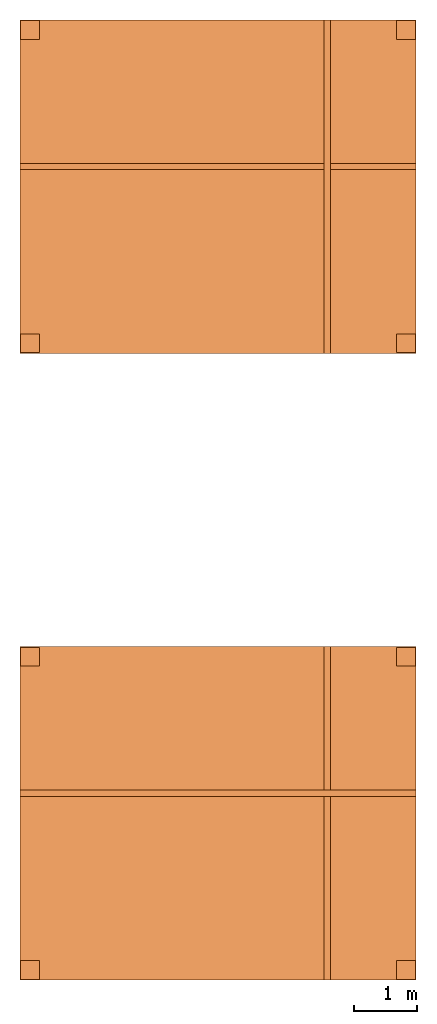
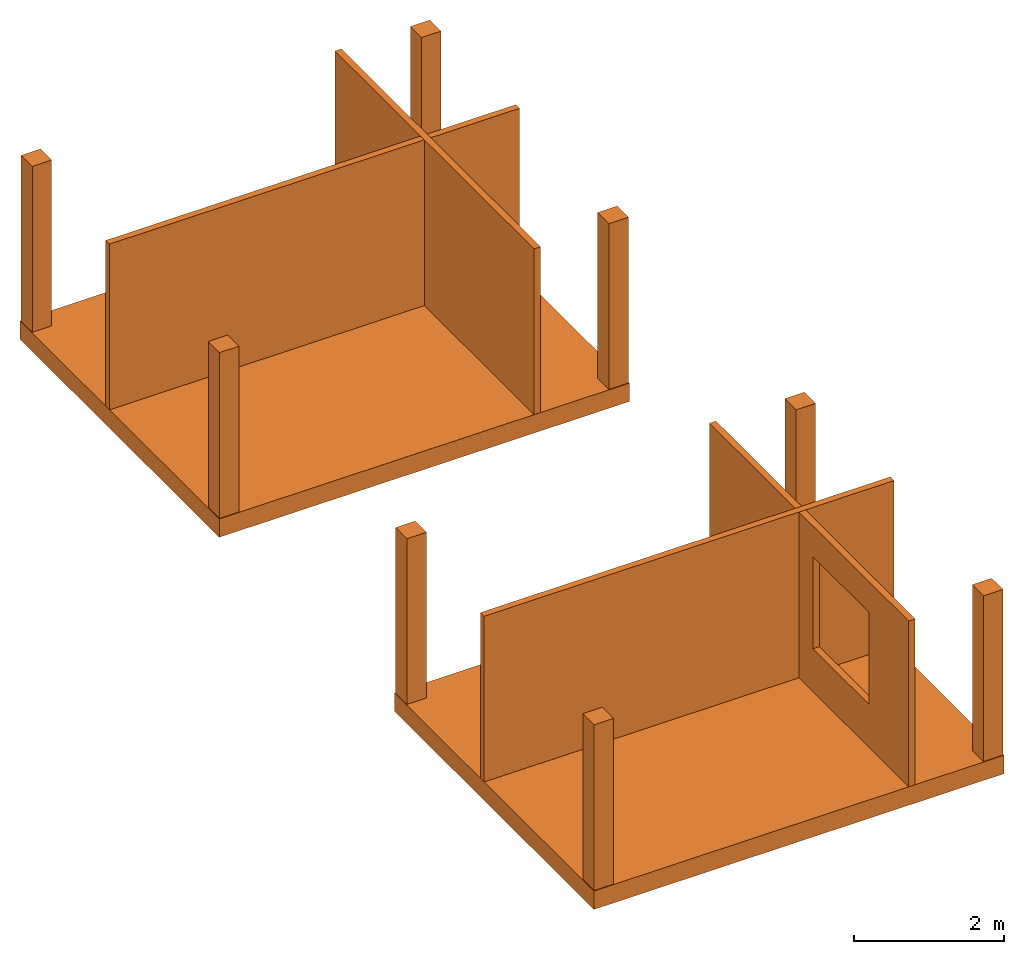
# One storey: 14 proxies, 1 opening.
"""IFC2X3 building model written with IfcOpenShell, lengths in metres."""

from ifc_helpers import new_model, entity, si_unit, converted_unit, derived_unit, money_unit, direction, frame, origin_with_axes, origin_2d_with_axis, place, context, subcontext, project, spatial, polyline, rectangle, outline, extrude, material, type_object, element, save


model = new_model("IFC2X3")

# Units and contexts
model_context = context("Model", 3, precision=1e-05, world=origin_with_axes(), true_north=direction((0.0, 1.0)))
body_context = subcontext(model_context, "Body", "Model", "MODEL_VIEW")
ifc_project = project(units=[si_unit("LENGTHUNIT", "METRE"), si_unit("AREAUNIT", "SQUARE_METRE"), si_unit("VOLUMEUNIT", "CUBIC_METRE"), converted_unit("PLANEANGLEUNIT", "DEGREE", entity("IfcPlaneAngleMeasure", 0.0174532925199433), si_unit("PLANEANGLEUNIT", "RADIAN"), dimensions=[0, 0, 0, 0, 0, 0, 0]), money_unit("EUR"), converted_unit("TIMEUNIT", "Year", entity("IfcTimeMeasure", 31557600.0), si_unit("TIMEUNIT", "SECOND"), dimensions=[0, 0, 1, 0, 0, 0, 0]), si_unit("MASSUNIT", "GRAM", prefix="KILO"), si_unit("THERMODYNAMICTEMPERATUREUNIT", "DEGREE_CELSIUS"), si_unit("LUMINOUSINTENSITYUNIT", "LUMEN"), si_unit("ENERGYUNIT", "JOULE", prefix="MEGA"), derived_unit("THERMALCONDUCTANCEUNIT", [(si_unit("POWERUNIT", "WATT"), 1), (si_unit("LENGTHUNIT", "METRE"), -1), (si_unit("THERMODYNAMICTEMPERATUREUNIT", "KELVIN"), -1)]), derived_unit("SPECIFICHEATCAPACITYUNIT", [(si_unit("ENERGYUNIT", "JOULE"), 1), (si_unit("MASSUNIT", "GRAM", prefix="KILO"), -1), (si_unit("THERMODYNAMICTEMPERATUREUNIT", "KELVIN"), -1)]), derived_unit("MASSDENSITYUNIT", [(si_unit("MASSUNIT", "GRAM", prefix="KILO"), 1), (si_unit("VOLUMEUNIT", "CUBIC_METRE"), -1)])], contexts=[model_context])

# Site, building, storey
site_placement = place(None, origin_with_axes())
site = spatial("IfcSite", under=ifc_project, at=site_placement, CompositionType="ELEMENT")
building_placement = place(site_placement, origin_with_axes())
building = spatial("IfcBuilding", under=site, at=building_placement, Name="Edificio", CompositionType="ELEMENT")
storey_placement = place(building_placement, frame((0.0, 0.0, 3.0), z_axis=(0.0, 0.0, 1.0), x_axis=(1.0, 0.0, 0.0)))
storey = spatial("IfcBuildingStorey", under=building, at=storey_placement, Name="L01", CompositionType="ELEMENT", Elevation=3.0)

# Proxies
ifc_material_1 = material(Name="Cemento - Strutturale")
building_element_proxy_type_1 = type_object("IfcBuildingElementProxyType", Name="Cemento - Strutturale 300", PredefinedType="NOTDEFINED")
for number, where, z_axis, x_axis, name in (
    (1, (-0.16, -0.16, 0.0), (0.0, 0.0, 1.0), (1.0, 0.0, 0.0), "SOL_001"),
    (2, (-0.1599999999999991, 9.84, 0.0), (0.0, 0.0, 1.0), (1.0, 0.0, 0.0), "SOL_005"),
):
    element("IfcBuildingElementProxy", number, at=place(storey_placement, frame(where, z_axis=z_axis, x_axis=x_axis)), inside=storey, type_object=building_element_proxy_type_1, material=ifc_material_1, Name=name, context=body_context, shape_type="SweptSolid", body=[
        extrude(outline(polyline([(0.0, 0.0), (6.32, 0.0), (6.32, 5.32), (0.0, 5.32), (0.0, 0.0)])), frame((0.0, 0.0, -0.3), z_axis=(0.0, 0.0, 1.0), x_axis=(1.0, 0.0, 0.0)), (0.0, 0.0, 1.0), 0.3),
    ])
ifc_material_2 = material(Name="Mattone")
building_element_proxy_type_2 = type_object("IfcBuildingElementProxyType", Name="Mattone 100", PredefinedType="NOTDEFINED")
proxy_1_placement = place(storey_placement, frame((-0.16, 2.771048843802536, 0.0), z_axis=(0.0, 0.0, 1.0), x_axis=(1.0, 0.0, 0.0)))
element("IfcBuildingElementProxy", 3, at=proxy_1_placement, inside=storey, type_object=building_element_proxy_type_2, material=ifc_material_2, Name="MUR_010", context=body_context, shape_type="SweptSolid", body=[
    extrude(outline(polyline([(0.0, 0.0), (6.32, 0.0), (6.32, 0.1000000000000001), (0.0, 0.1000000000000001), (0.0, 0.0)])), origin_with_axes(), (0.0, 0.0, 1.0), 2.7),
])

# Proxy, opening
proxy_2_placement = place(storey_placement, frame((4.69193911373474, 5.16, 0.0), z_axis=(0.0, 0.0, 1.0), x_axis=(0.0, -1.0, 0.0)))
proxy_2 = element("IfcBuildingElementProxy", 4, at=proxy_2_placement, inside=storey, type_object=building_element_proxy_type_2, material=ifc_material_2, Name="MUR_011", context=body_context, shape_type="SweptSolid", body=[
    extrude(outline(polyline([(0.0, 0.0), (5.32, 0.0), (5.32, 0.09999999999999964), (0.0, 0.09999999999999964), (0.0, 0.0)])), origin_with_axes(), (0.0, 0.0, 1.0), 2.7),
])
opening_placement = place(proxy_2_placement, frame((5.16, -4.69193911373474, -3.0), z_axis=(0.0, 0.0, 1.0), x_axis=(0.0, 1.0, 0.0)))
element("IfcOpeningElement", 5, at=opening_placement, cuts=proxy_2, Name="AP - 001", ObjectType="Empty Opening", context=body_context, shape_type="SweptSolid", body=[
    extrude(rectangle(XDim=1.5, YDim=1.5, at=origin_2d_with_axis()), frame((4.591939113734741, 1.645887335946943, 4.450122148049859), z_axis=(-1.0, 0.0, 0.0), x_axis=(0.0, -1.0, 0.0)), (0.0, 0.0, -1.0), 0.2999999999999989),
])

# Proxies
proxy_3_placement = place(storey_placement, frame((-0.1599999999999991, 12.77104884380254, 0.0), z_axis=(0.0, 0.0, 1.0), x_axis=(1.0, 0.0, 0.0)))
element("IfcBuildingElementProxy", 6, at=proxy_3_placement, inside=storey, type_object=building_element_proxy_type_2, material=ifc_material_2, Name="MUR_021", context=body_context, shape_type="SweptSolid", body=[
    extrude(outline(polyline([(0.0, 0.0), (6.32, 0.0), (6.32, 0.09999999999999964), (0.0, 0.09999999999999964), (0.0, 0.0)])), origin_with_axes(), (0.0, 0.0, 1.0), 2.7),
])
proxy_4_placement = place(storey_placement, frame((4.691939113734741, 15.16, 0.0), z_axis=(0.0, 0.0, 1.0), x_axis=(0.0, -1.0, 0.0)))
element("IfcBuildingElementProxy", 7, at=proxy_4_placement, inside=storey, type_object=building_element_proxy_type_2, material=ifc_material_2, Name="MUR_022", context=body_context, shape_type="SweptSolid", body=[
    extrude(outline(polyline([(0.0, 0.0), (5.32, 0.0), (5.32, 0.09999999999999964), (0.0, 0.09999999999999964), (0.0, 0.0)])), origin_with_axes(), (0.0, 0.0, 1.0), 2.7),
])
ifc_material_3 = material(Name="Cemento Strutturale")
building_element_proxy_type_3 = type_object("IfcBuildingElementProxyType", Name="Cemento Strutturale 300 x 300", PredefinedType="NOTDEFINED")
for number, where, z_axis, x_axis, name in (
    (8, (0.0, 0.0, 0.0), (0.0, 0.0, 1.0), (1.0, 0.0, 0.0), "PIL_001"),
    (9, (6.0, 0.0, 0.0), (0.0, 0.0, 1.0), (1.0, 0.0, 0.0), "PIL_002"),
    (10, (0.0, 5.0, 0.0), (0.0, 0.0, 1.0), (1.0, 0.0, 0.0), "PIL_003"),
    (11, (6.0, 5.0, 0.0), (0.0, 0.0, 1.0), (1.0, 0.0, 0.0), "PIL_004"),
    (12, (0.0, 10.0, 0.0), (0.0, 0.0, 1.0), (1.0, 0.0, 0.0), "PIL_009"),
    (13, (6.000000000000001, 10.0, 0.0), (0.0, 0.0, 1.0), (1.0, 0.0, 0.0), "PIL_010"),
    (14, (0.0, 15.0, 0.0), (0.0, 0.0, 1.0), (1.0, 0.0, 0.0), "PIL_011"),
    (15, (6.000000000000001, 15.0, 0.0), (0.0, 0.0, 1.0), (1.0, 0.0, 0.0), "PIL_012"),
):
    element("IfcBuildingElementProxy", number, at=place(storey_placement, frame(where, z_axis=z_axis, x_axis=x_axis)), inside=storey, type_object=building_element_proxy_type_3, material=ifc_material_3, Name=name, context=body_context, shape_type="SweptSolid", body=[
        extrude(rectangle(XDim=0.3, YDim=0.3, at=origin_2d_with_axis()), origin_with_axes(), (0.0, 0.0, 1.0), 2.7),
    ])

save(model, "model.ifc")
